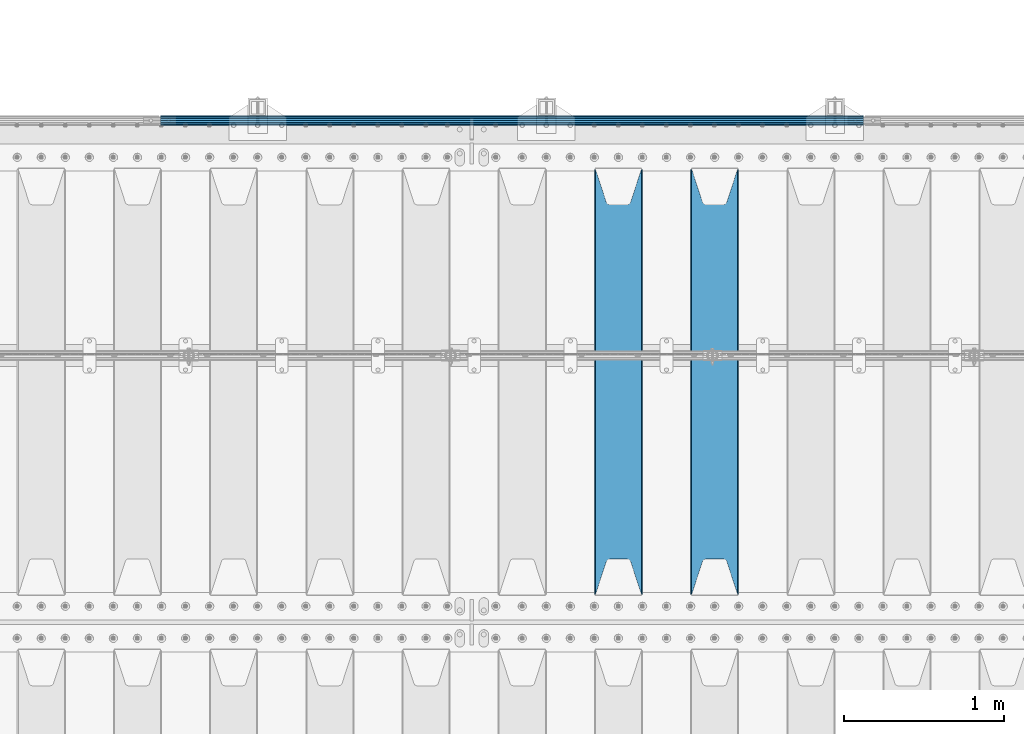
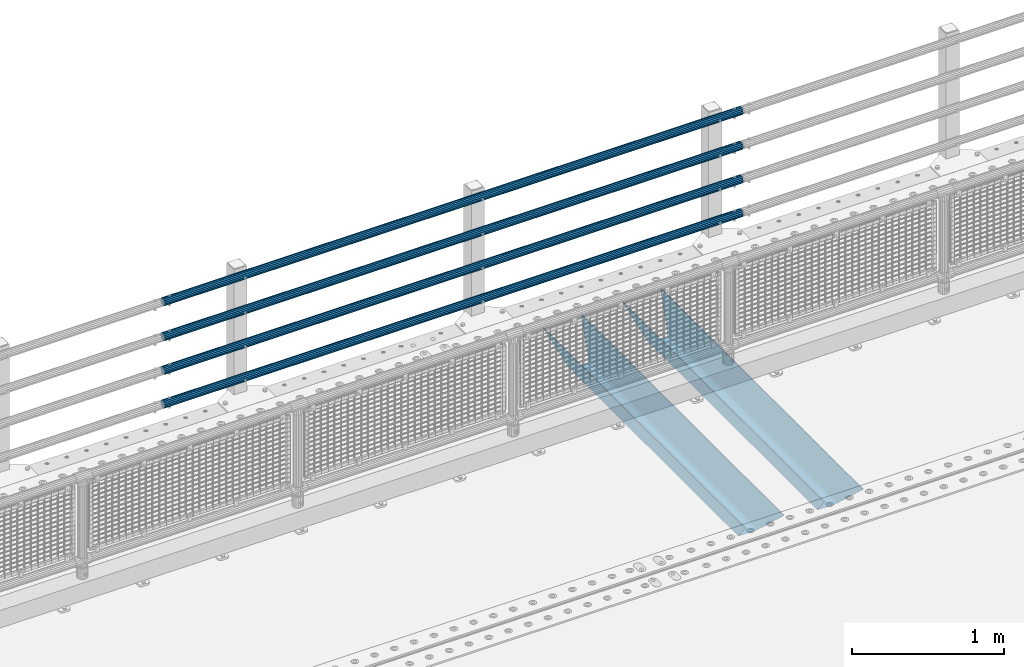
# One storey, part 133 of 270: 6 beams.
"""IFC2X3 building model written with IfcOpenShell, lengths in millimetres."""

from ifc_helpers import new_model, si_unit, frame, origin_with_axes, place, context, subcontext, project, spatial, faceted_brep, material, type_object, element, save


model = new_model("IFC2X3")

# Units and contexts
model_context = context("Model", 3, precision=1e-05, world=origin_with_axes())
body_context = subcontext(model_context, "Body", "Model", "MODEL_VIEW")
ifc_project = project(units=[si_unit("LENGTHUNIT", "METRE", prefix="MILLI"), si_unit("AREAUNIT", "SQUARE_METRE"), si_unit("VOLUMEUNIT", "CUBIC_METRE"), si_unit("MASSUNIT", "GRAM", prefix="KILO"), si_unit("TIMEUNIT", "SECOND"), si_unit("PLANEANGLEUNIT", "RADIAN"), si_unit("SOLIDANGLEUNIT", "STERADIAN"), si_unit("THERMODYNAMICTEMPERATUREUNIT", "DEGREE_CELSIUS"), si_unit("LUMINOUSINTENSITYUNIT", "LUMEN")], contexts=[model_context])

# Site, building, storey
site_placement = place(None, origin_with_axes())
site = spatial("IfcSite", under=ifc_project, at=site_placement, CompositionType="ELEMENT")
building_placement = place(site_placement, origin_with_axes())
building = spatial("IfcBuilding", under=site, at=building_placement, Name="Standard", CompositionType="ELEMENT")
storey_placement = place(building_placement, origin_with_axes())
storey = spatial("IfcBuildingStorey", under=building, at=storey_placement, Name="Undefined", CompositionType="ELEMENT", Elevation=0.0)

# Beams
ifc_material_1 = material()
beam_type_1 = type_object("IfcBeamType", PredefinedType="NOTDEFINED")
beam_1_placement = place(storey_placement, frame((9727.99999999987, -14870.1499999999, 149.849999999726), z_axis=(0.0, 0.0, -1.0), x_axis=(-1.0, 0.0, 0.0)))
element("IfcBeam", 1, at=beam_1_placement, inside=storey, type_object=beam_type_1, material=ifc_material_1, context=body_context, shape_type="Brep", body=[
    faceted_brep([(0.0, -26.5499999999993, 0.0), (0.0, -24.5290015881747, 10.1602451292931), (4384.00249699992, -24.5290015881747, 10.1602451292931), (4384.00249699992, -26.5499999999993, 0.0), (0.0, -18.7736850405036, 18.7736850405028), (4384.00249699992, -18.7736850405036, 18.7736850405028), (0.0, -10.1602451292929, 24.5290015881747), (4384.00249699992, -10.1602451292929, 24.5290015881747), (0.0, 0.0, 26.55), (4384.00249699992, 0.0, 26.55), (0.0, 10.1602451292929, 24.5290015881747), (4384.00249699992, 10.1602451292929, 24.5290015881747), (0.0, 18.7736850405036, 18.7736850405028), (4384.00249699992, 18.7736850405036, 18.7736850405028), (0.0, 24.5290015881747, 10.1602451292931), (4384.00249699992, 24.5290015881747, 10.1602451292931), (0.0, 26.5499999999993, 0.0), (4384.00249699992, 26.5499999999993, 0.0), (0.0, 24.5290015881747, -10.1602451292931), (4384.00249699992, 24.5290015881747, -10.1602451292931), (0.0, 18.7736850405036, -18.7736850405028), (4384.00249699992, 18.7736850405036, -18.7736850405028), (0.0, 10.1602451292929, -24.5290015881747), (4384.00249699992, 10.1602451292929, -24.5290015881747), (0.0, 0.0, -26.55), (4384.00249699992, 0.0, -26.55), (0.0, -10.1602451292929, -24.5290015881747), (4384.00249699992, -10.1602451292929, -24.5290015881747), (0.0, -18.7736850405036, -18.7736850405028), (4384.00249699992, -18.7736850405036, -18.7736850405028), (0.0, -24.5290015881747, -10.1602451292931), (4384.00249699992, -24.5290015881747, -10.1602451292931), (0.0, -30.1499999999996, 0.0), (0.0, -27.8549679052157, -11.5379054858058), (4384.00249699992, -27.8549679052157, -11.5379054858075), (4384.00249699992, -30.1499999999996, 0.0), (0.0, -21.3192694527752, -21.3192694527752), (4384.00249699992, -21.3192694527752, -21.3192694527744), (0.0, -11.5379054858076, -27.8549679052157), (4384.00249699992, -11.5379054858076, -27.8549679052153), (0.0, 0.0, -30.1500000000015), (4384.00249699992, 0.0, -30.15), (0.0, 11.5379054858076, -27.8549679052157), (4384.00249699992, 11.5379054858076, -27.8549679052153), (0.0, 21.3192694527752, -21.3192694527752), (4384.00249699992, 21.3192694527752, -21.3192694527744), (0.0, 27.8549679052157, -11.5379054858058), (4384.00249699992, 27.8549679052157, -11.5379054858074), (0.0, 30.1499999999996, 0.0), (4384.00249699992, 30.1499999999996, 0.0), (0.0, 27.8549679052157, 11.5379054858058), (4384.00249699992, 27.8549679052157, 11.5379054858075), (0.0, 21.3192694527752, 21.3192694527752), (4384.00249699992, 21.3192694527752, 21.3192694527744), (0.0, 11.5379054858076, 27.8549679052157), (4384.00249699992, 11.5379054858076, 27.8549679052153), (0.0, 0.0, 30.1500000000015), (4384.00249699992, 0.0, 30.15), (0.0, -11.5379054858076, 27.8549679052157), (4384.00249699992, -11.5379054858076, 27.8549679052153), (0.0, -21.3192694527752, 21.3192694527752), (4384.00249699992, -21.3192694527752, 21.3192694527744), (0.0, -27.8549679052157, 11.5379054858058), (4384.00249699992, -27.8549679052157, 11.5379054858075)], [[[0, 1, 2, 3]], [[1, 4, 5, 2]], [[4, 6, 7, 5]], [[6, 8, 9, 7]], [[8, 10, 11, 9]], [[10, 12, 13, 11]], [[12, 14, 15, 13]], [[14, 16, 17, 15]], [[16, 18, 19, 17]], [[18, 20, 21, 19]], [[20, 22, 23, 21]], [[22, 24, 25, 23]], [[24, 26, 27, 25]], [[26, 28, 29, 27]], [[28, 30, 31, 29]], [[30, 0, 3, 31]], [[32, 33, 34, 35]], [[33, 36, 37, 34]], [[36, 38, 39, 37]], [[38, 40, 41, 39]], [[40, 42, 43, 41]], [[42, 44, 45, 43]], [[44, 46, 47, 45]], [[46, 48, 49, 47]], [[48, 50, 51, 49]], [[50, 52, 53, 51]], [[52, 54, 55, 53]], [[54, 56, 57, 55]], [[56, 58, 59, 57]], [[58, 60, 61, 59]], [[60, 62, 63, 61]], [[62, 32, 35, 63]], [[37, 39, 41, 43, 45, 47, 49, 51, 53, 55, 57, 59, 61, 63, 35, 34], [5, 7, 9, 11, 13, 15, 17, 19, 21, 23, 25, 27, 29, 31, 3, 2]], [[62, 60, 58, 56, 54, 52, 50, 48, 46, 44, 42, 40, 38, 36, 33, 32], [30, 28, 26, 24, 22, 20, 18, 16, 14, 12, 10, 8, 6, 4, 1, 0]]]),
])
beam_2_placement = place(storey_placement, frame((9727.99999999987, -14870.1499999999, 420.149999999729), z_axis=(0.0, 0.0, -1.0), x_axis=(-1.0, 0.0, 0.0)))
element("IfcBeam", 2, at=beam_2_placement, inside=storey, type_object=beam_type_1, material=ifc_material_1, context=body_context, shape_type="Brep", body=[
    faceted_brep([(0.0, -26.5499999999993, 0.0), (0.0, -24.5290015881747, 10.1602451292931), (4384.00249699992, -24.5290015881747, 10.1602451292931), (4384.00249699992, -26.5499999999993, 0.0), (0.0, -18.7736850405036, 18.7736850405028), (4384.00249699992, -18.7736850405036, 18.7736850405028), (0.0, -10.1602451292929, 24.5290015881747), (4384.00249699992, -10.1602451292929, 24.5290015881747), (0.0, 0.0, 26.55), (4384.00249699992, 0.0, 26.55), (0.0, 10.1602451292929, 24.5290015881747), (4384.00249699992, 10.1602451292929, 24.5290015881747), (0.0, 18.7736850405036, 18.7736850405028), (4384.00249699992, 18.7736850405036, 18.7736850405028), (0.0, 24.5290015881747, 10.1602451292931), (4384.00249699992, 24.5290015881747, 10.1602451292931), (0.0, 26.5499999999993, 0.0), (4384.00249699992, 26.5499999999993, 0.0), (0.0, 24.5290015881747, -10.1602451292931), (4384.00249699992, 24.5290015881747, -10.1602451292931), (0.0, 18.7736850405036, -18.7736850405028), (4384.00249699992, 18.7736850405036, -18.7736850405028), (0.0, 10.1602451292929, -24.5290015881747), (4384.00249699992, 10.1602451292929, -24.5290015881747), (0.0, 0.0, -26.55), (4384.00249699992, 0.0, -26.55), (0.0, -10.1602451292929, -24.5290015881747), (4384.00249699992, -10.1602451292929, -24.5290015881747), (0.0, -18.7736850405036, -18.7736850405028), (4384.00249699992, -18.7736850405036, -18.7736850405028), (0.0, -24.5290015881747, -10.1602451292931), (4384.00249699992, -24.5290015881747, -10.1602451292931), (0.0, -30.1499999999996, 0.0), (0.0, -27.8549679052157, -11.5379054858058), (4384.00249699992, -27.8549679052157, -11.5379054858075), (4384.00249699992, -30.1499999999996, 0.0), (0.0, -21.3192694527752, -21.3192694527752), (4384.00249699992, -21.3192694527752, -21.3192694527744), (0.0, -11.5379054858076, -27.8549679052157), (4384.00249699992, -11.5379054858076, -27.8549679052153), (0.0, 0.0, -30.1500000000015), (4384.00249699992, 0.0, -30.15), (0.0, 11.5379054858076, -27.8549679052157), (4384.00249699992, 11.5379054858076, -27.8549679052153), (0.0, 21.3192694527752, -21.3192694527752), (4384.00249699992, 21.3192694527752, -21.3192694527744), (0.0, 27.8549679052157, -11.5379054858058), (4384.00249699992, 27.8549679052157, -11.5379054858074), (0.0, 30.1499999999996, 0.0), (4384.00249699992, 30.1499999999996, 0.0), (0.0, 27.8549679052157, 11.5379054858058), (4384.00249699992, 27.8549679052157, 11.5379054858075), (0.0, 21.3192694527752, 21.3192694527752), (4384.00249699992, 21.3192694527752, 21.3192694527744), (0.0, 11.5379054858076, 27.8549679052157), (4384.00249699992, 11.5379054858076, 27.8549679052153), (0.0, 0.0, 30.1500000000015), (4384.00249699992, 0.0, 30.15), (0.0, -11.5379054858076, 27.8549679052157), (4384.00249699992, -11.5379054858076, 27.8549679052153), (0.0, -21.3192694527752, 21.3192694527752), (4384.00249699992, -21.3192694527752, 21.3192694527744), (0.0, -27.8549679052157, 11.5379054858058), (4384.00249699992, -27.8549679052157, 11.5379054858075)], [[[0, 1, 2, 3]], [[1, 4, 5, 2]], [[4, 6, 7, 5]], [[6, 8, 9, 7]], [[8, 10, 11, 9]], [[10, 12, 13, 11]], [[12, 14, 15, 13]], [[14, 16, 17, 15]], [[16, 18, 19, 17]], [[18, 20, 21, 19]], [[20, 22, 23, 21]], [[22, 24, 25, 23]], [[24, 26, 27, 25]], [[26, 28, 29, 27]], [[28, 30, 31, 29]], [[30, 0, 3, 31]], [[32, 33, 34, 35]], [[33, 36, 37, 34]], [[36, 38, 39, 37]], [[38, 40, 41, 39]], [[40, 42, 43, 41]], [[42, 44, 45, 43]], [[44, 46, 47, 45]], [[46, 48, 49, 47]], [[48, 50, 51, 49]], [[50, 52, 53, 51]], [[52, 54, 55, 53]], [[54, 56, 57, 55]], [[56, 58, 59, 57]], [[58, 60, 61, 59]], [[60, 62, 63, 61]], [[62, 32, 35, 63]], [[37, 39, 41, 43, 45, 47, 49, 51, 53, 55, 57, 59, 61, 63, 35, 34], [5, 7, 9, 11, 13, 15, 17, 19, 21, 23, 25, 27, 29, 31, 3, 2]], [[62, 60, 58, 56, 54, 52, 50, 48, 46, 44, 42, 40, 38, 36, 33, 32], [30, 28, 26, 24, 22, 20, 18, 16, 14, 12, 10, 8, 6, 4, 1, 0]]]),
])
beam_3_placement = place(storey_placement, frame((9727.99999999987, -14870.1499999999, 969.849999999726), z_axis=(0.0, 0.0, -1.0), x_axis=(-1.0, 0.0, 0.0)))
element("IfcBeam", 3, at=beam_3_placement, inside=storey, type_object=beam_type_1, material=ifc_material_1, context=body_context, shape_type="Brep", body=[
    faceted_brep([(0.0, -26.5499999999993, 0.0), (0.0, -24.5290015881747, 10.1602451292931), (4384.00249699992, -24.5290015881747, 10.1602451292931), (4384.00249699992, -26.5499999999993, 0.0), (0.0, -18.7736850405036, 18.7736850405028), (4384.00249699992, -18.7736850405036, 18.7736850405028), (0.0, -10.1602451292929, 24.5290015881747), (4384.00249699992, -10.1602451292929, 24.5290015881747), (0.0, 0.0, 26.55), (4384.00249699992, 0.0, 26.55), (0.0, 10.1602451292929, 24.5290015881747), (4384.00249699992, 10.1602451292929, 24.5290015881747), (0.0, 18.7736850405036, 18.7736850405028), (4384.00249699992, 18.7736850405036, 18.7736850405028), (0.0, 24.5290015881747, 10.1602451292931), (4384.00249699992, 24.5290015881747, 10.1602451292931), (0.0, 26.5499999999993, 0.0), (4384.00249699992, 26.5499999999993, 0.0), (0.0, 24.5290015881747, -10.1602451292931), (4384.00249699992, 24.5290015881747, -10.1602451292931), (0.0, 18.7736850405036, -18.7736850405028), (4384.00249699992, 18.7736850405036, -18.7736850405028), (0.0, 10.1602451292929, -24.5290015881747), (4384.00249699992, 10.1602451292929, -24.5290015881747), (0.0, 0.0, -26.55), (4384.00249699992, 0.0, -26.55), (0.0, -10.1602451292929, -24.5290015881747), (4384.00249699992, -10.1602451292929, -24.5290015881747), (0.0, -18.7736850405036, -18.7736850405028), (4384.00249699992, -18.7736850405036, -18.7736850405028), (0.0, -24.5290015881747, -10.1602451292931), (4384.00249699992, -24.5290015881747, -10.1602451292931), (0.0, -30.1499999999996, 0.0), (0.0, -27.8549679052157, -11.5379054858058), (4384.00249699992, -27.8549679052157, -11.5379054858075), (4384.00249699992, -30.1499999999996, 0.0), (0.0, -21.3192694527752, -21.3192694527752), (4384.00249699992, -21.3192694527752, -21.3192694527744), (0.0, -11.5379054858076, -27.8549679052157), (4384.00249699992, -11.5379054858076, -27.8549679052153), (0.0, 0.0, -30.1500000000015), (4384.00249699992, 0.0, -30.15), (0.0, 11.5379054858076, -27.8549679052157), (4384.00249699992, 11.5379054858076, -27.8549679052153), (0.0, 21.3192694527752, -21.3192694527752), (4384.00249699992, 21.3192694527752, -21.3192694527744), (0.0, 27.8549679052157, -11.5379054858058), (4384.00249699992, 27.8549679052157, -11.5379054858074), (0.0, 30.1499999999996, 0.0), (4384.00249699992, 30.1499999999996, 0.0), (0.0, 27.8549679052157, 11.5379054858058), (4384.00249699992, 27.8549679052157, 11.5379054858075), (0.0, 21.3192694527752, 21.3192694527752), (4384.00249699992, 21.3192694527752, 21.3192694527744), (0.0, 11.5379054858076, 27.8549679052157), (4384.00249699992, 11.5379054858076, 27.8549679052153), (0.0, 0.0, 30.1500000000015), (4384.00249699992, 0.0, 30.15), (0.0, -11.5379054858076, 27.8549679052157), (4384.00249699992, -11.5379054858076, 27.8549679052153), (0.0, -21.3192694527752, 21.3192694527752), (4384.00249699992, -21.3192694527752, 21.3192694527744), (0.0, -27.8549679052157, 11.5379054858058), (4384.00249699992, -27.8549679052157, 11.5379054858075)], [[[0, 1, 2, 3]], [[1, 4, 5, 2]], [[4, 6, 7, 5]], [[6, 8, 9, 7]], [[8, 10, 11, 9]], [[10, 12, 13, 11]], [[12, 14, 15, 13]], [[14, 16, 17, 15]], [[16, 18, 19, 17]], [[18, 20, 21, 19]], [[20, 22, 23, 21]], [[22, 24, 25, 23]], [[24, 26, 27, 25]], [[26, 28, 29, 27]], [[28, 30, 31, 29]], [[30, 0, 3, 31]], [[32, 33, 34, 35]], [[33, 36, 37, 34]], [[36, 38, 39, 37]], [[38, 40, 41, 39]], [[40, 42, 43, 41]], [[42, 44, 45, 43]], [[44, 46, 47, 45]], [[46, 48, 49, 47]], [[48, 50, 51, 49]], [[50, 52, 53, 51]], [[52, 54, 55, 53]], [[54, 56, 57, 55]], [[56, 58, 59, 57]], [[58, 60, 61, 59]], [[60, 62, 63, 61]], [[62, 32, 35, 63]], [[37, 39, 41, 43, 45, 47, 49, 51, 53, 55, 57, 59, 61, 63, 35, 34], [5, 7, 9, 11, 13, 15, 17, 19, 21, 23, 25, 27, 29, 31, 3, 2]], [[62, 60, 58, 56, 54, 52, 50, 48, 46, 44, 42, 40, 38, 36, 33, 32], [30, 28, 26, 24, 22, 20, 18, 16, 14, 12, 10, 8, 6, 4, 1, 0]]]),
])
beam_4_placement = place(storey_placement, frame((9727.99999999987, -14870.1499999999, 689.849999999726), z_axis=(0.0, 0.0, -1.0), x_axis=(-1.0, 0.0, 0.0)))
element("IfcBeam", 4, at=beam_4_placement, inside=storey, type_object=beam_type_1, material=ifc_material_1, context=body_context, shape_type="Brep", body=[
    faceted_brep([(0.0, -26.5499999999993, 0.0), (0.0, -24.5290015881747, 10.1602451292931), (4384.00249699992, -24.5290015881747, 10.1602451292931), (4384.00249699992, -26.5499999999993, 0.0), (0.0, -18.7736850405036, 18.7736850405028), (4384.00249699992, -18.7736850405036, 18.7736850405028), (0.0, -10.1602451292929, 24.5290015881747), (4384.00249699992, -10.1602451292929, 24.5290015881747), (0.0, 0.0, 26.55), (4384.00249699992, 0.0, 26.55), (0.0, 10.1602451292929, 24.5290015881747), (4384.00249699992, 10.1602451292929, 24.5290015881747), (0.0, 18.7736850405036, 18.7736850405028), (4384.00249699992, 18.7736850405036, 18.7736850405028), (0.0, 24.5290015881747, 10.1602451292931), (4384.00249699992, 24.5290015881747, 10.1602451292931), (0.0, 26.5499999999993, 0.0), (4384.00249699992, 26.5499999999993, 0.0), (0.0, 24.5290015881747, -10.1602451292931), (4384.00249699992, 24.5290015881747, -10.1602451292931), (0.0, 18.7736850405036, -18.7736850405028), (4384.00249699992, 18.7736850405036, -18.7736850405028), (0.0, 10.1602451292929, -24.5290015881747), (4384.00249699992, 10.1602451292929, -24.5290015881747), (0.0, 0.0, -26.55), (4384.00249699992, 0.0, -26.55), (0.0, -10.1602451292929, -24.5290015881747), (4384.00249699992, -10.1602451292929, -24.5290015881747), (0.0, -18.7736850405036, -18.7736850405028), (4384.00249699992, -18.7736850405036, -18.7736850405028), (0.0, -24.5290015881747, -10.1602451292931), (4384.00249699992, -24.5290015881747, -10.1602451292931), (0.0, -30.1499999999996, 0.0), (0.0, -27.8549679052157, -11.5379054858058), (4384.00249699992, -27.8549679052157, -11.5379054858075), (4384.00249699992, -30.1499999999996, 0.0), (0.0, -21.3192694527752, -21.3192694527752), (4384.00249699992, -21.3192694527752, -21.3192694527744), (0.0, -11.5379054858076, -27.8549679052157), (4384.00249699992, -11.5379054858076, -27.8549679052153), (0.0, 0.0, -30.1500000000015), (4384.00249699992, 0.0, -30.15), (0.0, 11.5379054858076, -27.8549679052157), (4384.00249699992, 11.5379054858076, -27.8549679052153), (0.0, 21.3192694527752, -21.3192694527752), (4384.00249699992, 21.3192694527752, -21.3192694527744), (0.0, 27.8549679052157, -11.5379054858058), (4384.00249699992, 27.8549679052157, -11.5379054858074), (0.0, 30.1499999999996, 0.0), (4384.00249699992, 30.1499999999996, 0.0), (0.0, 27.8549679052157, 11.5379054858058), (4384.00249699992, 27.8549679052157, 11.5379054858075), (0.0, 21.3192694527752, 21.3192694527752), (4384.00249699992, 21.3192694527752, 21.3192694527744), (0.0, 11.5379054858076, 27.8549679052157), (4384.00249699992, 11.5379054858076, 27.8549679052153), (0.0, 0.0, 30.1500000000015), (4384.00249699992, 0.0, 30.15), (0.0, -11.5379054858076, 27.8549679052157), (4384.00249699992, -11.5379054858076, 27.8549679052153), (0.0, -21.3192694527752, 21.3192694527752), (4384.00249699992, -21.3192694527752, 21.3192694527744), (0.0, -27.8549679052157, 11.5379054858058), (4384.00249699992, -27.8549679052157, 11.5379054858075)], [[[0, 1, 2, 3]], [[1, 4, 5, 2]], [[4, 6, 7, 5]], [[6, 8, 9, 7]], [[8, 10, 11, 9]], [[10, 12, 13, 11]], [[12, 14, 15, 13]], [[14, 16, 17, 15]], [[16, 18, 19, 17]], [[18, 20, 21, 19]], [[20, 22, 23, 21]], [[22, 24, 25, 23]], [[24, 26, 27, 25]], [[26, 28, 29, 27]], [[28, 30, 31, 29]], [[30, 0, 3, 31]], [[32, 33, 34, 35]], [[33, 36, 37, 34]], [[36, 38, 39, 37]], [[38, 40, 41, 39]], [[40, 42, 43, 41]], [[42, 44, 45, 43]], [[44, 46, 47, 45]], [[46, 48, 49, 47]], [[48, 50, 51, 49]], [[50, 52, 53, 51]], [[52, 54, 55, 53]], [[54, 56, 57, 55]], [[56, 58, 59, 57]], [[58, 60, 61, 59]], [[60, 62, 63, 61]], [[62, 32, 35, 63]], [[37, 39, 41, 43, 45, 47, 49, 51, 53, 55, 57, 59, 61, 63, 35, 34], [5, 7, 9, 11, 13, 15, 17, 19, 21, 23, 25, 27, 29, 31, 3, 2]], [[62, 60, 58, 56, 54, 52, 50, 48, 46, 44, 42, 40, 38, 36, 33, 32], [30, 28, 26, 24, 22, 20, 18, 16, 14, 12, 10, 8, 6, 4, 1, 0]]]),
])
ifc_material_2 = material(Name="STEEL/S355N")
beam_type_2 = type_object("IfcBeamType", PredefinedType="NOTDEFINED")
beam_5_placement = place(storey_placement, frame((8800.0, -17825.0, -115.0), z_axis=(0.0, 0.0, 1.0), x_axis=(0.0, 1.0, 0.0)))
element("IfcBeam", 5, at=beam_5_placement, inside=storey, type_object=beam_type_2, material=ifc_material_2, context=body_context, shape_type="Brep", body=[
    faceted_brep([(0.0, 150.0, 115.0), (0.0, 143.689999999999, 115.0), (2650.00000000297, 143.689999999999, 115.0), (2650.00000000297, 150.0, 115.0), (2650.00000000297, 142.059565218398, 110.000000003096), (2650.00000000297, 148.3695652184, 110.000000003096), (2441.90079219209, -80.1103600731112, -98.0992078077845), (2437.7588105432, -77.5672621345584, -102.241189456673), (2434.06523489747, -74.4080125315522, -105.934765102404), (2430.9108609509, -70.710272125576, -109.089139048974), (2428.37322971128, -66.5649389910068, -111.626770288588), (2426.51472138055, -62.0739139532889, -113.485278619323), (2425.38102192092, -57.3475956567672, -114.618978078955), (2424.99999999987, -52.5021667386536, -115.0), (2424.99999999987, 52.5021667386536, -115.0), (2425.38102192092, 57.3475956567672, -114.618978078955), (2426.51472138055, 62.0739139532889, -113.485278619323), (2428.37322971128, 66.5649389910068, -111.626770288588), (2430.9108609509, 70.710272125576, -109.089139048974), (2434.06523489747, 74.4080125315522, -105.934765102404), (2437.7588105432, 77.5672621345584, -102.241189456673), (2441.90079219209, 80.1103600731112, -98.0992078077846), (2446.38936140511, 81.9747917625791, -93.6106385947584), (2448.2494850041, 76.2713538057251, -91.7505149957729), (2444.62967112263, 74.76777986261, -95.3703288772456), (2441.28936334126, 72.7168944282894, -98.710636658607), (2438.31067330439, 70.1691124903846, -101.689326695487), (2435.76682334747, 67.1870637758839, -104.233176652398), (2433.72034654133, 63.8440531834895, -106.279653458539), (2432.22154950042, 60.222258798236, -107.778450499454), (2431.30727574265, 56.4107117849089, -108.692724257221), (2430.99999999987, 52.5031078186876, -109.0), (2430.99999999987, -52.5031078186876, -109.0), (2431.30727574265, -56.4107117849089, -108.692724257221), (2432.22154950042, -60.222258798236, -107.778450499454), (2433.72034654133, -63.8440531834895, -106.279653458539), (2435.76682334747, -67.1870637758839, -104.233176652398), (2438.31067330438, -70.1691124903846, -101.689326695487), (2441.28936334126, -72.7168944282894, -98.7106366586071), (2444.62967112263, -74.76777986261, -95.3703288772457), (2448.2494850041, -76.2713538057251, -91.7505149957729), (2650.00000000297, -142.059565218398, 110.000000003096), (2650.00000000297, -148.3695652184, 110.000000003096), (2446.38936140511, -81.9747917625791, -93.6106385947584), (2650.00000000297, -143.689999999999, 115.0), (2650.00000000297, -150.0, 115.0), (0.0, -143.689999999999, 115.0), (0.0, -150.0, 115.0), (0.0, -148.369565218261, 110.000000002672), (203.610638597431, -81.9747917625791, -93.6106385947584), (208.099207810457, -80.1103600731112, -98.0992078077845), (212.241189459342, -77.5672621345584, -102.241189456673), (215.934765105078, -74.4080125315522, -105.934765102404), (219.089139051644, -70.710272125576, -109.089139048974), (221.626770291259, -66.5649389910068, -111.626770288588), (223.485278621993, -62.0739139532889, -113.485278619323), (224.618978081628, -57.3475956567672, -114.618978078955), (225.00000000267, -52.5021667386536, -115.0), (225.00000000267, 52.5021667386536, -115.0), (224.618978081628, 57.3475956567672, -114.618978078955), (223.485278621993, 62.0739139532889, -113.485278619323), (221.626770291259, 66.5649389910068, -111.626770288588), (219.089139051644, 70.710272125576, -109.089139048974), (215.934765105078, 74.4080125315522, -105.934765102404), (212.241189459342, 77.5672621345584, -102.241189456673), (208.099207810457, 80.1103600731112, -98.0992078077846), (203.610638597431, 81.9747917625791, -93.6106385947584), (0.0, 148.369565218261, 110.000000002672), (0.0, 142.05956521826, 110.000000002672), (201.750514998446, 76.2713538057251, -91.7505149957729), (205.370328879915, 74.76777986261, -95.3703288772456), (208.710636661279, 72.7168944282894, -98.710636658607), (211.689326698157, 70.1691124903846, -101.689326695487), (214.233176655071, 67.1870637758839, -104.233176652398), (216.27965346121, 63.8440531834895, -106.279653458539), (217.778450502126, 60.222258798236, -107.778450499454), (218.692724259894, 56.4107117849089, -108.692724257221), (219.00000000267, 52.5031078186876, -109.0), (219.00000000267, -52.5031078186876, -109.0), (218.692724259894, -56.4107117849089, -108.692724257221), (217.778450502123, -60.222258798236, -107.778450499454), (216.27965346121, -63.8440531834895, -106.279653458539), (214.233176655071, -67.1870637758839, -104.233176652398), (211.689326698157, -70.1691124903846, -101.689326695487), (208.710636661279, -72.7168944282894, -98.7106366586071), (205.370328879915, -74.76777986261, -95.3703288772457), (201.750514998446, -76.2713538057251, -91.7505149957729), (0.0, -142.05956521826, 110.000000002672)], [[[0, 1, 2, 3]], [[3, 2, 4, 5]], [[6, 7, 8, 9, 10, 11, 12, 13, 14, 15, 16, 17, 18, 19, 20, 21, 22, 5, 4, 23, 24, 25, 26, 27, 28, 29, 30, 31, 32, 33, 34, 35, 36, 37, 38, 39, 40, 41, 42, 43]], [[44, 45, 42, 41]], [[46, 47, 45, 44]], [[43, 42, 45, 47, 48, 49]], [[6, 43, 49, 50]], [[7, 6, 50, 51]], [[8, 7, 51, 52]], [[9, 8, 52, 53]], [[10, 9, 53, 54]], [[11, 10, 54, 55]], [[12, 11, 55, 56]], [[13, 12, 56, 57]], [[14, 13, 57, 58]], [[15, 14, 58, 59]], [[16, 15, 59, 60]], [[17, 16, 60, 61]], [[18, 17, 61, 62]], [[19, 18, 62, 63]], [[20, 19, 63, 64]], [[21, 20, 64, 65]], [[22, 21, 65, 66]], [[0, 3, 5, 22, 66, 67]], [[1, 0, 67, 68]], [[23, 4, 2, 1, 68, 69]], [[24, 23, 69, 70]], [[25, 24, 70, 71]], [[26, 25, 71, 72]], [[27, 26, 72, 73]], [[28, 27, 73, 74]], [[29, 28, 74, 75]], [[30, 29, 75, 76]], [[31, 30, 76, 77]], [[32, 31, 77, 78]], [[33, 32, 78, 79]], [[34, 33, 79, 80]], [[35, 34, 80, 81]], [[36, 35, 81, 82]], [[37, 36, 82, 83]], [[38, 37, 83, 84]], [[39, 38, 84, 85]], [[40, 39, 85, 86]], [[46, 44, 41, 40, 86, 87]], [[47, 46, 87, 48]], [[86, 85, 84, 83, 82, 81, 80, 79, 78, 77, 76, 75, 74, 73, 72, 71, 70, 69, 68, 67, 66, 65, 64, 63, 62, 61, 60, 59, 58, 57, 56, 55, 54, 53, 52, 51, 50, 49, 48, 87]]]),
])
beam_6_placement = place(storey_placement, frame((8200.0, -17825.0, -115.0), z_axis=(0.0, 0.0, 1.0), x_axis=(0.0, 1.0, 0.0)))
element("IfcBeam", 6, at=beam_6_placement, inside=storey, type_object=beam_type_2, material=ifc_material_2, context=body_context, shape_type="Brep", body=[
    faceted_brep([(0.0, 150.0, 115.0), (0.0, 143.689999999999, 115.0), (2650.00000000297, 143.689999999999, 115.0), (2650.00000000297, 150.0, 115.0), (2650.00000000297, 142.059565218398, 110.000000003096), (2650.00000000297, 148.3695652184, 110.000000003096), (2441.90079219209, -80.1103600731112, -98.0992078077845), (2437.7588105432, -77.5672621345584, -102.241189456673), (2434.06523489747, -74.4080125315522, -105.934765102404), (2430.9108609509, -70.710272125576, -109.089139048974), (2428.37322971128, -66.5649389910068, -111.626770288588), (2426.51472138055, -62.0739139532889, -113.485278619323), (2425.38102192092, -57.3475956567672, -114.618978078955), (2424.99999999987, -52.5021667386536, -115.0), (2424.99999999987, 52.5021667386536, -115.0), (2425.38102192092, 57.3475956567672, -114.618978078955), (2426.51472138055, 62.0739139532889, -113.485278619323), (2428.37322971128, 66.5649389910068, -111.626770288588), (2430.9108609509, 70.710272125576, -109.089139048974), (2434.06523489747, 74.4080125315522, -105.934765102404), (2437.7588105432, 77.5672621345584, -102.241189456673), (2441.90079219209, 80.1103600731112, -98.0992078077846), (2446.38936140511, 81.9747917625791, -93.6106385947584), (2448.2494850041, 76.2713538057251, -91.7505149957729), (2444.62967112263, 74.76777986261, -95.3703288772456), (2441.28936334126, 72.7168944282894, -98.710636658607), (2438.31067330439, 70.1691124903846, -101.689326695487), (2435.76682334747, 67.1870637758839, -104.233176652398), (2433.72034654133, 63.8440531834895, -106.279653458539), (2432.22154950042, 60.222258798236, -107.778450499454), (2431.30727574265, 56.4107117849089, -108.692724257221), (2430.99999999987, 52.5031078186876, -109.0), (2430.99999999987, -52.5031078186876, -109.0), (2431.30727574265, -56.4107117849089, -108.692724257221), (2432.22154950042, -60.222258798236, -107.778450499454), (2433.72034654133, -63.8440531834895, -106.279653458539), (2435.76682334747, -67.1870637758839, -104.233176652398), (2438.31067330438, -70.1691124903846, -101.689326695487), (2441.28936334126, -72.7168944282894, -98.7106366586071), (2444.62967112263, -74.76777986261, -95.3703288772457), (2448.2494850041, -76.2713538057251, -91.7505149957729), (2650.00000000297, -142.059565218398, 110.000000003096), (2650.00000000297, -148.3695652184, 110.000000003096), (2446.38936140511, -81.9747917625791, -93.6106385947584), (2650.00000000297, -143.689999999999, 115.0), (2650.00000000297, -150.0, 115.0), (0.0, -143.689999999999, 115.0), (0.0, -150.0, 115.0), (0.0, -148.369565218261, 110.000000002672), (203.610638597431, -81.9747917625791, -93.6106385947584), (208.099207810457, -80.1103600731112, -98.0992078077845), (212.241189459342, -77.5672621345584, -102.241189456673), (215.934765105078, -74.4080125315522, -105.934765102404), (219.089139051644, -70.710272125576, -109.089139048974), (221.626770291259, -66.5649389910068, -111.626770288588), (223.485278621993, -62.0739139532889, -113.485278619323), (224.618978081628, -57.3475956567672, -114.618978078955), (225.00000000267, -52.5021667386536, -115.0), (225.00000000267, 52.5021667386536, -115.0), (224.618978081628, 57.3475956567672, -114.618978078955), (223.485278621993, 62.0739139532889, -113.485278619323), (221.626770291259, 66.5649389910068, -111.626770288588), (219.089139051644, 70.710272125576, -109.089139048974), (215.934765105078, 74.4080125315522, -105.934765102404), (212.241189459342, 77.5672621345584, -102.241189456673), (208.099207810457, 80.1103600731112, -98.0992078077846), (203.610638597431, 81.9747917625791, -93.6106385947584), (0.0, 148.369565218261, 110.000000002672), (0.0, 142.05956521826, 110.000000002672), (201.750514998446, 76.2713538057251, -91.7505149957729), (205.370328879915, 74.76777986261, -95.3703288772456), (208.710636661279, 72.7168944282894, -98.710636658607), (211.689326698157, 70.1691124903846, -101.689326695487), (214.233176655071, 67.1870637758839, -104.233176652398), (216.27965346121, 63.8440531834895, -106.279653458539), (217.778450502126, 60.222258798236, -107.778450499454), (218.692724259894, 56.4107117849089, -108.692724257221), (219.00000000267, 52.5031078186876, -109.0), (219.00000000267, -52.5031078186876, -109.0), (218.692724259894, -56.4107117849089, -108.692724257221), (217.778450502123, -60.222258798236, -107.778450499454), (216.27965346121, -63.8440531834895, -106.279653458539), (214.233176655071, -67.1870637758839, -104.233176652398), (211.689326698157, -70.1691124903846, -101.689326695487), (208.710636661279, -72.7168944282894, -98.7106366586071), (205.370328879915, -74.76777986261, -95.3703288772457), (201.750514998446, -76.2713538057251, -91.7505149957729), (0.0, -142.05956521826, 110.000000002672)], [[[0, 1, 2, 3]], [[3, 2, 4, 5]], [[6, 7, 8, 9, 10, 11, 12, 13, 14, 15, 16, 17, 18, 19, 20, 21, 22, 5, 4, 23, 24, 25, 26, 27, 28, 29, 30, 31, 32, 33, 34, 35, 36, 37, 38, 39, 40, 41, 42, 43]], [[44, 45, 42, 41]], [[46, 47, 45, 44]], [[43, 42, 45, 47, 48, 49]], [[6, 43, 49, 50]], [[7, 6, 50, 51]], [[8, 7, 51, 52]], [[9, 8, 52, 53]], [[10, 9, 53, 54]], [[11, 10, 54, 55]], [[12, 11, 55, 56]], [[13, 12, 56, 57]], [[14, 13, 57, 58]], [[15, 14, 58, 59]], [[16, 15, 59, 60]], [[17, 16, 60, 61]], [[18, 17, 61, 62]], [[19, 18, 62, 63]], [[20, 19, 63, 64]], [[21, 20, 64, 65]], [[22, 21, 65, 66]], [[0, 3, 5, 22, 66, 67]], [[1, 0, 67, 68]], [[23, 4, 2, 1, 68, 69]], [[24, 23, 69, 70]], [[25, 24, 70, 71]], [[26, 25, 71, 72]], [[27, 26, 72, 73]], [[28, 27, 73, 74]], [[29, 28, 74, 75]], [[30, 29, 75, 76]], [[31, 30, 76, 77]], [[32, 31, 77, 78]], [[33, 32, 78, 79]], [[34, 33, 79, 80]], [[35, 34, 80, 81]], [[36, 35, 81, 82]], [[37, 36, 82, 83]], [[38, 37, 83, 84]], [[39, 38, 84, 85]], [[40, 39, 85, 86]], [[46, 44, 41, 40, 86, 87]], [[47, 46, 87, 48]], [[86, 85, 84, 83, 82, 81, 80, 79, 78, 77, 76, 75, 74, 73, 72, 71, 70, 69, 68, 67, 66, 65, 64, 63, 62, 61, 60, 59, 58, 57, 56, 55, 54, 53, 52, 51, 50, 49, 48, 87]]]),
])

save(model, "model.ifc")
